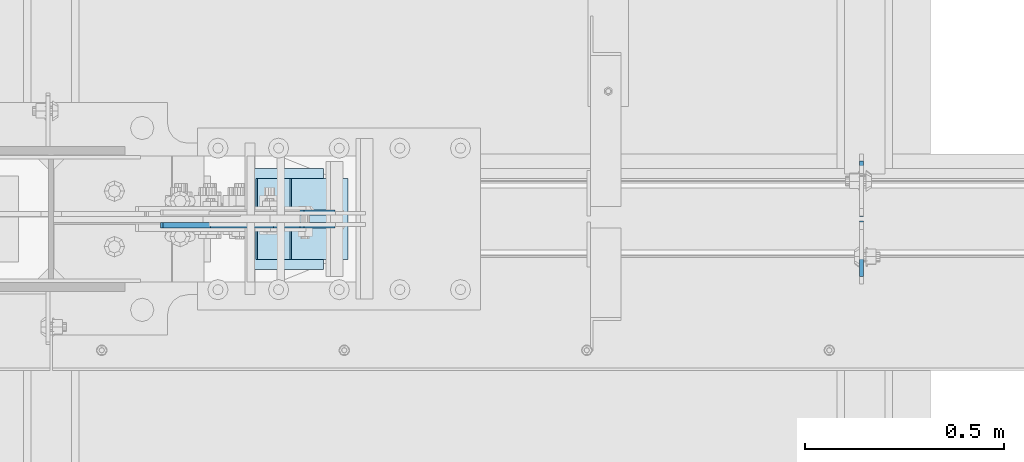
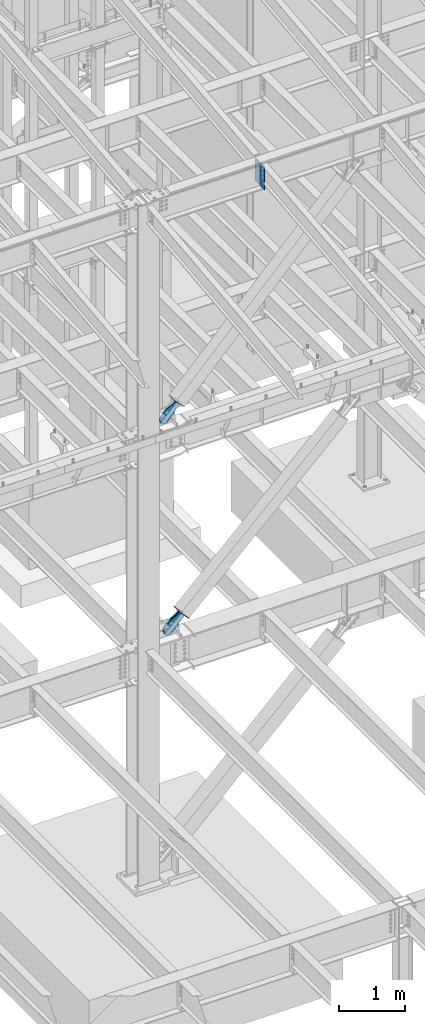
# One storey, part 1029 of 1179: 8 plates, 7 elements without a shape of their own.
"""IFC2X3 building model written with IfcOpenShell, lengths in millimetres."""

import ifcopenshell
import ifcopenshell.guid

model = None  # the IFC model being written
_history = None  # IfcOwnerHistory: only IFC2X3 demands one
_inside = {}  # id of a spatial element -> (the spatial element, [elements in it])
_under = {}  # id of a project, library or spatial element -> (it, [spatial elements below it])
_declared = {}  # id of a project -> (the project, [libraries it declares])
_typed = {}  # id of a type object -> (the type object, [elements of that type])
_made_of = {}  # id of a material, layer set ... -> (it, [elements and type objects made of it])


def new_model(schema):
    """Start an empty IFC model of exactly this schema.

    Asked for "IFC4X3", IfcOpenShell would pick the latest addendum, in which some entities
    have other attributes; the version numbers below select the first issue.
    IFC2X3 requires an IfcOwnerHistory on every rooted entity: one is made here for all.
    """
    global model, _history
    if schema == "IFC4X3":
        model = ifcopenshell.file(schema_version=(4, 3, 0, 0))
    else:
        model = ifcopenshell.file(schema=schema)
    _inside.clear()
    _under.clear()
    _declared.clear()
    _typed.clear()
    _made_of.clear()
    _history = None
    if model.schema == "IFC2X3":
        org = make("IfcOrganization", Name="unknown")
        user = make(
            "IfcPersonAndOrganization",
            ThePerson=make("IfcPerson", FamilyName="unknown"),
            TheOrganization=org,
        )
        app = make(
            "IfcApplication",
            ApplicationDeveloper=org,
            Version="unknown",
            ApplicationFullName="unknown",
            ApplicationIdentifier="unknown",
        )
        _history = make(
            "IfcOwnerHistory",
            OwningUser=user,
            OwningApplication=app,
            ChangeAction="ADDED",
            CreationDate=0,
        )
    return model


def make(cls, **values):
    """One entity of the class cls with the attributes given. An attribute that is None is left unset."""
    return model.create_entity(
        cls, **{name: value for name, value in values.items() if value is not None}
    )


def rooted(cls, **values):
    """An entity with a GlobalId (a new one), such as an element, a storey or a relation."""
    return make(cls, GlobalId=ifcopenshell.guid.new(), OwnerHistory=_history, **values)


def si_unit(unit_type, name, prefix=None):
    """IfcSIUnit, for example si_unit("LENGTHUNIT", "METRE", prefix="MILLI")."""
    return make("IfcSIUnit", UnitType=unit_type, Prefix=prefix, Name=name)


def assignment(units):
    """IfcUnitAssignment: the units of a project."""
    return None if units is None else make("IfcUnitAssignment", Units=units)


def point(xyz):
    """IfcCartesianPoint."""
    return None if xyz is None else make("IfcCartesianPoint", Coordinates=xyz)


def direction(xyz):
    """IfcDirection."""
    return None if xyz is None else make("IfcDirection", DirectionRatios=xyz)


def frame(location, z_axis=None, x_axis=None):
    """IfcAxis2Placement3D, a coordinate frame: its origin and axes. An axis left out is left unset."""
    return make(
        "IfcAxis2Placement3D",
        Location=point(location),
        Axis=direction(z_axis),
        RefDirection=direction(x_axis),
    )


def origin_with_axes():
    """The frame at (0, 0, 0) with the z axis (0, 0, 1) and the x axis (1, 0, 0) written out."""
    return frame((0.0, 0.0, 0.0), z_axis=(0.0, 0.0, 1.0), x_axis=(1.0, 0.0, 0.0))


def place(relative_to, where):
    """IfcLocalPlacement: puts the frame where relative to a parent placement (None: the world)."""
    return make(
        "IfcLocalPlacement", PlacementRelTo=relative_to, RelativePlacement=where
    )


def context(
    kind, dimensions, precision=None, world=None, true_north=None, identifier=None
):
    """IfcGeometricRepresentationContext, for example the 3D "Model" context."""
    return make(
        "IfcGeometricRepresentationContext",
        ContextIdentifier=identifier,
        ContextType=kind,
        CoordinateSpaceDimension=dimensions,
        Precision=precision,
        WorldCoordinateSystem=world,
        TrueNorth=true_north,
    )


def subcontext(parent, identifier, kind, view, scale=None):
    """IfcGeometricRepresentationSubContext, for example "Body" below "Model"."""
    return make(
        "IfcGeometricRepresentationSubContext",
        ContextIdentifier=identifier,
        ContextType=kind,
        ParentContext=parent,
        TargetScale=scale,
        TargetView=view,
    )


def project(units=None, contexts=None):
    """IfcProject with its units and contexts."""
    return rooted(
        "IfcProject",
        Name="project",
        RepresentationContexts=contexts,
        UnitsInContext=assignment(units),
    )


def spatial(cls, under=None, at=None, **own):
    """A site, building, storey or space (cls), placed at a placement, below another one or the project."""
    s = rooted(cls, ObjectPlacement=at, **own)
    if under is not None:
        _under.setdefault(under.id(), (under, []))[1].append(s)
    return s


def faces_of(points, faces, orient=None, outer=None):
    """IfcFace entities. A face is a list of loops; a loop is a list of indices into points, from 0.

    orient and outer hold one flag for each loop. By default every Orientation is true, the
    first loop of a face is its IfcFaceOuterBound and the others are IfcFaceBound.
    """
    made = []
    for i, loops in enumerate(faces):
        bounds = []
        for j, loop in enumerate(loops):
            is_outer = j == 0 if outer is None else outer[i][j]
            bounds.append(
                make(
                    "IfcFaceOuterBound" if is_outer else "IfcFaceBound",
                    Bound=make("IfcPolyLoop", Polygon=[points[k] for k in loop]),
                    Orientation=True if orient is None else orient[i][j],
                )
            )
        made.append(make("IfcFace", Bounds=bounds))
    return made


def faceted_brep(points, faces, orient=None, outer=None, voids=None):
    """IfcFacetedBrep: a solid bounded by flat faces; with voids (closed shells), ...WithVoids."""
    shared = [point(p) for p in points]
    hull = make("IfcClosedShell", CfsFaces=faces_of(shared, faces, orient, outer))
    if voids is None:
        return make("IfcFacetedBrep", Outer=hull)
    return make(
        "IfcFacetedBrepWithVoids",
        Outer=hull,
        Voids=[
            make(cls, CfsFaces=faces_of(shared, fs, o, b)) for cls, fs, o, b in voids
        ],
    )


def shape(context_of_items, identifier, shape_type, items):
    """IfcShapeRepresentation: the items that make up one representation, for example the "Body"."""
    return make(
        "IfcShapeRepresentation",
        ContextOfItems=context_of_items,
        RepresentationIdentifier=identifier,
        RepresentationType=shape_type,
        Items=items,
    )


def material(Name=None, Category=None):
    """IfcMaterial."""
    return make("IfcMaterial", Name=Name, Category=Category)


def made_of(thing, what):
    """Note that an element or type object is made of a material, layer set ...; save() writes the relation."""
    if what is not None:
        _made_of.setdefault(what.id(), (what, []))[1].append(thing)
    return thing


def type_object(cls, material=None, **own):
    """A type object (cls), such as IfcWallType, which elements share."""
    return made_of(rooted(cls, **own), material)


def element(
    cls,
    number,
    at=None,
    inside=None,
    cuts=None,
    type_object=None,
    material=None,
    context=None,
    identifier="Body",
    shape_type=None,
    held_by="IfcProductDefinitionShape",
    body=None,
    shapes=None,
    **own,
):
    """One element of the class cls, such as IfcWall. Its Tag is "e" and its number.

    at: its placement. inside: the storey or other place that contains it. cuts: it is an
    opening in that element (IfcRelVoidsElement). A single representation is given by context,
    identifier, shape_type and body (its items); several are given by shapes. held_by: the class
    of the entity that holds the representations. save() writes the other relations.
    """
    e = rooted(cls, Tag="e%d" % number, ObjectPlacement=at, **own)
    if body is not None:
        shapes = [shape(context, identifier, shape_type, body)]
    if shapes is not None:
        e.Representation = make(held_by, Representations=shapes)
    if inside is not None:
        _inside.setdefault(inside.id(), (inside, []))[1].append(e)
    if cuts is not None:
        rooted(
            "IfcRelVoidsElement", RelatingBuildingElement=cuts, RelatedOpeningElement=e
        )
    if type_object is not None:
        _typed.setdefault(type_object.id(), (type_object, []))[1].append(e)
    return made_of(e, material)


def aggregate(whole, parts):
    """IfcRelAggregates: a whole, such as a stair, and the parts it consists of."""
    return rooted("IfcRelAggregates", RelatingObject=whole, RelatedObjects=parts)


def save(model, path):
    """Write the relations noted so far, then the file.

    IfcRelAggregates (storeys below a building ...), IfcRelContainedInSpatialStructure (elements
    in a storey), IfcRelDefinesByType, IfcRelAssociatesMaterial and IfcRelDeclares: one each for
    every whole, place, type object, material and project.
    """
    for whole, parts in _under.values():
        aggregate(whole, parts)
    for where, things in _inside.values():
        rooted(
            "IfcRelContainedInSpatialStructure",
            RelatedElements=things,
            RelatingStructure=where,
        )
    for kind, things in _typed.values():
        rooted("IfcRelDefinesByType", RelatedObjects=things, RelatingType=kind)
    for what, things in _made_of.values():
        rooted("IfcRelAssociatesMaterial", RelatedObjects=things, RelatingMaterial=what)
    for by, libraries in _declared.values():
        rooted("IfcRelDeclares", RelatingContext=by, RelatedDefinitions=libraries)
    model.write(path)


model = new_model("IFC2X3")

# Units and contexts
model_context = context("Model", 3, precision=1e-05, world=origin_with_axes())
body_context = subcontext(model_context, "Body", "Model", "MODEL_VIEW")
ifc_project = project(units=[si_unit("LENGTHUNIT", "METRE", prefix="MILLI"), si_unit("AREAUNIT", "SQUARE_METRE"), si_unit("VOLUMEUNIT", "CUBIC_METRE"), si_unit("MASSUNIT", "GRAM", prefix="KILO"), si_unit("TIMEUNIT", "SECOND"), si_unit("PLANEANGLEUNIT", "RADIAN"), si_unit("SOLIDANGLEUNIT", "STERADIAN"), si_unit("THERMODYNAMICTEMPERATUREUNIT", "DEGREE_CELSIUS"), si_unit("LUMINOUSINTENSITYUNIT", "LUMEN")], contexts=[model_context])

# Site, building, storey
site_placement = place(None, origin_with_axes())
site = spatial("IfcSite", under=ifc_project, at=site_placement, CompositionType="ELEMENT")
building_placement = place(site_placement, origin_with_axes())
building = spatial("IfcBuilding", under=site, at=building_placement, Name="Undefined", CompositionType="ELEMENT")
storey_placement = place(building_placement, origin_with_axes())
storey = spatial("IfcBuildingStorey", under=building, at=storey_placement, Name="Undefined", CompositionType="ELEMENT", Elevation=0.0)

# Assembly, plate
assembly_1_placement = place(storey_placement, origin_with_axes())
assembly_1 = element("IfcElementAssembly", 1, at=assembly_1_placement, inside=storey, AssemblyPlace="NOTDEFINED", PredefinedType="RIGID_FRAME")
ifc_material = material(Name="STEEL/A36")
plate_type_1 = type_object("IfcPlateType", PredefinedType="NOTDEFINED")
plate_1_placement = place(assembly_1_placement, frame((8848.95548700398, 27035.125, 8270.04204745431), z_axis=(-0.724386095169387, 0.0, 0.689394506161203), x_axis=(0.689394506161203, 0.0, 0.724386095169387)))
plate_1 = element("IfcPlate", 2, at=plate_1_placement, type_object=plate_type_1, material=ifc_material, context=body_context, shape_type="Brep", body=[
    faceted_brep([(0.0, -6.34999999999854, 0.0), (-101.600000000211, -6.34999999999854, -44.6881937825565), (-101.600000000211, 6.34999999999854, -44.6881937825565), (0.0, 6.34999999999854, 0.0), (-246.684985848258, -6.34999999999854, -44.6881937827675), (-246.684985848258, 6.34999999999854, -44.6881937827675), (-281.313054102191, -6.34999999999854, -37.800242748639), (-281.313054102191, 6.34999999999854, -37.800242748639), (-310.669312868691, -6.34999999999854, -18.1850177516608), (-310.669312868691, 6.34999999999854, -18.1850177516608), (-330.284537865713, -6.34999999999854, 11.1712410148393), (-330.284537865713, 6.34999999999854, 11.1712410148393), (-337.172488899912, -6.34999999999854, 45.7993031647638), (-337.172488899912, 6.34999999999854, 45.7993031647638), (-330.284537865768, -6.34999999999854, 80.4273714187839), (-330.284537865768, 6.34999999999854, 80.4273714187839), (-310.669312868773, -6.34999999999854, 109.783630185371), (-310.669312868773, 6.34999999999854, 109.783630185371), (-281.313054102271, -6.34999999999854, 129.398855182466), (-281.313054102271, 6.34999999999854, 129.398855182466), (-246.684988899762, -6.34999999999854, 136.286806216707), (-246.684988899762, 6.34999999999854, 136.286806216707), (-101.600000000377, -6.34999999999854, 136.286806216911), (-101.600000000377, 6.34999999999854, 136.286806216911), (-8.18545231595635e-11, -6.34999999999854, 91.5986124346418), (-8.18545231595635e-11, 6.34999999999854, 91.5986124346418), (82.5500000001266, -6.34999999999854, 91.5986124347546), (82.5500000001266, 6.34999999999854, 91.5986124347546), (82.550000000203, -6.34999999999854, 1.2732925824821e-10), (82.550000000203, 6.34999999999854, 1.2732925824821e-10)], [[[0, 1, 2, 3]], [[1, 4, 5, 2]], [[4, 6, 7, 5]], [[6, 8, 9, 7]], [[8, 10, 11, 9]], [[10, 12, 13, 11]], [[12, 14, 15, 13]], [[14, 16, 17, 15]], [[16, 18, 19, 17]], [[18, 20, 21, 19]], [[20, 22, 23, 21]], [[22, 24, 25, 23]], [[24, 26, 27, 25]], [[26, 28, 29, 27]], [[28, 0, 3, 29]], [[5, 7, 9, 11, 13, 15, 17, 19, 21, 23, 25, 27, 29, 3, 2]], [[28, 26, 24, 22, 20, 18, 16, 14, 12, 10, 8, 6, 4, 1, 0]]]),
])
aggregate(assembly_1, [plate_1])

assembly_2_placement = place(storey_placement, origin_with_axes())
assembly_2 = element("IfcElementAssembly", 3, at=assembly_2_placement, inside=storey, Name="Plate", AssemblyPlace="NOTDEFINED", PredefinedType="RIGID_FRAME")
plate_type_2 = type_object("IfcPlateType", PredefinedType="NOTDEFINED")
plate_2_placement = place(assembly_2_placement, frame((8944.0974226088, 26949.4, 8289.07150202462), z_axis=(-0.724386095169387, 0.0, 0.689394506161203), x_axis=(0.0, 1.0, 0.0)))
plate_2 = element("IfcPlate", 4, at=plate_2_placement, type_object=plate_type_2, material=ifc_material, Name="Plate", context=body_context, shape_type="Brep", body=[
    faceted_brep([(0.0, -3.17500000000109, 0.0), (0.0, -3.17500000000291, 203.200000000368), (0.0, 3.17499999998836, 203.200000000361), (0.0, 3.17500000000109, 7.27595761418343e-12), (203.199999999997, -3.17500000000291, 203.200000000368), (203.199999999997, 3.17499999998836, 203.200000000361), (203.199999999997, -3.17499999999927, 3.63797880709171e-12), (203.199999999997, 3.17499999999382, -3.63797880709171e-12)], [[[0, 1, 2, 3]], [[1, 4, 5, 2]], [[4, 6, 7, 5]], [[6, 0, 3, 7]], [[5, 7, 3, 2]], [[6, 4, 1, 0]]]),
])
aggregate(assembly_2, [plate_2])

assembly_3_placement = place(storey_placement, origin_with_axes())
assembly_3 = element("IfcElementAssembly", 5, at=assembly_3_placement, inside=storey, Name="Plate", AssemblyPlace="NOTDEFINED", PredefinedType="RIGID_FRAME")
plate_3_placement = place(assembly_3_placement, frame((9023.59478559862, 26949.4, 4367.90703055063), z_axis=(-0.694497308871752, 0.0, 0.719495300867138), x_axis=(0.0, 1.0, 0.0)))
plate_3 = element("IfcPlate", 6, at=plate_3_placement, type_object=plate_type_2, material=ifc_material, Name="Plate", context=body_context, shape_type="Brep", body=[
    faceted_brep([(0.0, -3.17500000000109, 0.0), (0.0, -3.17500000000291, 203.200000000368), (0.0, 3.17499999998836, 203.200000000361), (0.0, 3.17500000000109, 7.27595761418343e-12), (203.199999999997, -3.17500000000291, 203.200000000368), (203.199999999997, 3.17499999998836, 203.200000000361), (203.199999999997, -3.17499999999927, 3.63797880709171e-12), (203.199999999997, 3.17499999999382, -3.63797880709171e-12)], [[[0, 1, 2, 3]], [[1, 4, 5, 2]], [[4, 6, 7, 5]], [[6, 0, 3, 7]], [[5, 7, 3, 2]], [[6, 4, 1, 0]]]),
])
aggregate(assembly_3, [plate_3])

# Assembly, plates
assembly_4_placement = place(storey_placement, origin_with_axes())
assembly_4 = element("IfcElementAssembly", 7, at=assembly_4_placement, inside=storey, Name="BEAM", AssemblyPlace="NOTDEFINED", PredefinedType="RIGID_FRAME")
plate_type_3 = type_object("IfcPlateType", PredefinedType="NOTDEFINED")
plate_4_placement = place(assembly_4_placement, frame((10317.1620000839, 27045.4437499701, 11823.3031250357), z_axis=(0.0, 0.0, 1.0), x_axis=(0.0, -1.0, 0.0)))
plate_4 = element("IfcPlate", 8, at=plate_4_placement, type_object=plate_type_3, material=ifc_material, Name="PLATE", context=body_context, shape_type="Brep", body=[
    faceted_brep([(-1.81898940354586e-12, -4.76249999999345, 17.4624996185303), (0.0, -4.76250000000073, 407.98750038147), (0.0, 4.76250000000073, 407.98750038147), (1.81898940354586e-12, 4.76250000000073, 17.4624996185303), (17.4624996185303, -4.76250000000073, 425.450000000001), (17.4624996185303, 4.76250000000073, 425.450000000001), (139.699999999997, -4.76250000000073, 425.450000000001), (139.699999999997, 4.76250000000073, 425.450000000001), (139.7, -4.76249999999982, 0.0), (139.7, 4.76249999999982, 0.0), (17.4624996185157, -4.76250000000073, 0.0), (17.4624996185212, 4.76249999999345, 0.0)], [[[0, 1, 2, 3]], [[1, 4, 5, 2]], [[4, 6, 7, 5]], [[6, 8, 9, 7]], [[8, 10, 11, 9]], [[10, 0, 3, 11]], [[5, 7, 9, 11, 3, 2]], [[10, 8, 6, 4, 1, 0]]]),
])
plate_5_placement = place(assembly_4_placement, frame((10317.1620000839, 27056.5562499701, 11823.3031250357), z_axis=(0.0, 0.0, 1.0), x_axis=(0.0, 1.0, 0.0)))
plate_5 = element("IfcPlate", 9, at=plate_5_placement, type_object=plate_type_3, material=ifc_material, Name="PLATE", context=body_context, shape_type="Brep", body=[
    faceted_brep([(-1.81898940354586e-12, -4.76249999999345, 17.4624996185303), (0.0, -4.76250000000073, 407.98750038147), (0.0, 4.76250000000073, 407.98750038147), (1.81898940354586e-12, 4.76250000000073, 17.4624996185303), (17.4624996185303, -4.76250000000073, 425.450000000001), (17.4624996185303, 4.76250000000073, 425.450000000001), (139.699999999997, -4.76250000000073, 425.450000000001), (139.699999999997, 4.76250000000073, 425.450000000001), (139.7, -4.76249999999982, 0.0), (139.7, 4.76249999999982, 0.0), (17.4624996185157, -4.76250000000073, 0.0), (17.4624996185212, 4.76249999999345, 0.0)], [[[0, 1, 2, 3]], [[1, 4, 5, 2]], [[4, 6, 7, 5]], [[6, 8, 9, 7]], [[8, 10, 11, 9]], [[10, 0, 3, 11]], [[5, 7, 9, 11, 3, 2]], [[10, 8, 6, 4, 1, 0]]]),
])
aggregate(assembly_4, [plate_4, plate_5])

# Assembly, plate
assembly_5_placement = place(storey_placement, origin_with_axes())
assembly_5 = element("IfcElementAssembly", 10, at=assembly_5_placement, inside=storey, AssemblyPlace="NOTDEFINED", PredefinedType="RIGID_FRAME")
plate_type_4 = type_object("IfcPlateType", PredefinedType="NOTDEFINED")
plate_6_placement = place(assembly_5_placement, frame((8934.87998578012, 27066.875, 4345.52376395533), z_axis=(-0.694497308871752, 0.0, 0.719495300867138), x_axis=(0.719495300867139, 0.0, 0.694497308871752)))
plate_6 = element("IfcPlate", 11, at=plate_6_placement, type_object=plate_type_4, material=ifc_material, context=body_context, shape_type="Brep", body=[
    faceted_brep([(0.0, -6.34999999999854, 0.0), (-101.599999999963, -6.34999999999854, -37.5700345970108), (-101.599999999963, 6.34999999999854, -37.5700345970108), (0.0, 6.34999999999854, 0.0), (-245.369242323884, -6.34999999999854, -37.5700345970945), (-245.369242323884, 6.34999999999854, -37.5700345970945), (-281.212328723803, -6.34999999999854, -30.4404014271258), (-281.212328723803, 6.34999999999854, -30.4404014271258), (-311.598630137756, -6.34999999999854, -10.1369239370142), (-311.598630137756, 6.34999999999854, -10.1369239370142), (-331.902107627997, -6.34999999999854, 20.24937747687), (-331.902107627997, 6.34999999999854, 20.24937747687), (-339.031740798124, -6.34999999999854, 56.0924669287269), (-339.031740798124, 6.34999999999854, 56.0924669287269), (-331.902107628228, -6.34999999999854, 91.9355533287926), (-331.902107628228, 6.34999999999854, 91.9355533287926), (-311.598630138099, -6.34999999999854, 122.321854742866), (-311.598630138099, 6.34999999999854, 122.321854742866), (-281.212328724136, -6.34999999999854, 142.625332233139), (-281.212328724136, 6.34999999999854, 142.625332233139), (-245.36924079839, -6.34999999999854, 149.754965403199), (-245.36924079839, 6.34999999999854, 149.754965403199), (-101.600000000685, -6.34999999999854, 149.75496540329), (-101.600000000685, 6.34999999999854, 149.75496540329), (-4.35647962149233e-10, -6.34999999999854, 112.184930806416), (-4.35647962149233e-10, 6.34999999999854, 112.184930806416), (82.5499999996491, -6.34999999999854, 112.184930806461), (82.5499999996491, 6.34999999999854, 112.184930806461), (82.550000000203, -6.34999999999854, 1.2732925824821e-10), (82.550000000203, 6.34999999999854, 1.2732925824821e-10)], [[[0, 1, 2, 3]], [[1, 4, 5, 2]], [[4, 6, 7, 5]], [[6, 8, 9, 7]], [[8, 10, 11, 9]], [[10, 12, 13, 11]], [[12, 14, 15, 13]], [[14, 16, 17, 15]], [[16, 18, 19, 17]], [[18, 20, 21, 19]], [[20, 22, 23, 21]], [[22, 24, 25, 23]], [[24, 26, 27, 25]], [[26, 28, 29, 27]], [[28, 0, 3, 29]], [[5, 7, 9, 11, 13, 15, 17, 19, 21, 23, 25, 27, 29, 3, 2]], [[28, 26, 24, 22, 20, 18, 16, 14, 12, 10, 8, 6, 4, 1, 0]]]),
])
aggregate(assembly_5, [plate_6])

assembly_6_placement = place(storey_placement, origin_with_axes())
assembly_6 = element("IfcElementAssembly", 12, at=assembly_6_placement, inside=storey, AssemblyPlace="NOTDEFINED", PredefinedType="RIGID_FRAME")
plate_7_placement = place(assembly_6_placement, frame((8934.87998578012, 27035.125, 4345.52376395533), z_axis=(-0.694497308871752, 0.0, 0.719495300867138), x_axis=(0.719495300867139, 0.0, 0.694497308871752)))
plate_7 = element("IfcPlate", 13, at=plate_7_placement, type_object=plate_type_4, material=ifc_material, context=body_context, shape_type="Brep", body=[
    faceted_brep([(0.0, -6.34999999999854, 0.0), (-101.599999999963, -6.34999999999854, -37.5700345970108), (-101.599999999963, 6.34999999999854, -37.5700345970108), (0.0, 6.34999999999854, 0.0), (-245.369242323884, -6.34999999999854, -37.5700345970945), (-245.369242323884, 6.34999999999854, -37.5700345970945), (-281.212328723803, -6.34999999999854, -30.4404014271258), (-281.212328723803, 6.34999999999854, -30.4404014271258), (-311.598630137756, -6.34999999999854, -10.1369239370142), (-311.598630137756, 6.34999999999854, -10.1369239370142), (-331.902107627997, -6.34999999999854, 20.24937747687), (-331.902107627997, 6.34999999999854, 20.24937747687), (-339.031740798124, -6.34999999999854, 56.0924669287269), (-339.031740798124, 6.34999999999854, 56.0924669287269), (-331.902107628228, -6.34999999999854, 91.9355533287926), (-331.902107628228, 6.34999999999854, 91.9355533287926), (-311.598630138099, -6.34999999999854, 122.321854742866), (-311.598630138099, 6.34999999999854, 122.321854742866), (-281.212328724136, -6.34999999999854, 142.625332233139), (-281.212328724136, 6.34999999999854, 142.625332233139), (-245.36924079839, -6.34999999999854, 149.754965403199), (-245.36924079839, 6.34999999999854, 149.754965403199), (-101.600000000685, -6.34999999999854, 149.75496540329), (-101.600000000685, 6.34999999999854, 149.75496540329), (-4.35647962149233e-10, -6.34999999999854, 112.184930806416), (-4.35647962149233e-10, 6.34999999999854, 112.184930806416), (82.5499999996491, -6.34999999999854, 112.184930806461), (82.5499999996491, 6.34999999999854, 112.184930806461), (82.550000000203, -6.34999999999854, 1.2732925824821e-10), (82.550000000203, 6.34999999999854, 1.2732925824821e-10)], [[[0, 1, 2, 3]], [[1, 4, 5, 2]], [[4, 6, 7, 5]], [[6, 8, 9, 7]], [[8, 10, 11, 9]], [[10, 12, 13, 11]], [[12, 14, 15, 13]], [[14, 16, 17, 15]], [[16, 18, 19, 17]], [[18, 20, 21, 19]], [[20, 22, 23, 21]], [[22, 24, 25, 23]], [[24, 26, 27, 25]], [[26, 28, 29, 27]], [[28, 0, 3, 29]], [[5, 7, 9, 11, 13, 15, 17, 19, 21, 23, 25, 27, 29, 3, 2]], [[28, 26, 24, 22, 20, 18, 16, 14, 12, 10, 8, 6, 4, 1, 0]]]),
])
aggregate(assembly_6, [plate_7])

assembly_7_placement = place(storey_placement, origin_with_axes())
assembly_7 = element("IfcElementAssembly", 14, at=assembly_7_placement, inside=storey, Name="Plate", AssemblyPlace="NOTDEFINED", PredefinedType="RIGID_FRAME")
plate_type_5 = type_object("IfcPlateType", PredefinedType="NOTDEFINED")
plate_8_placement = place(assembly_7_placement, frame((8963.12193986124, 26924.0, 275.238706534023), z_axis=(-0.699860687134476, 0.0, 0.714279370137245), x_axis=(0.0, 1.0, 0.0)))
plate_8 = element("IfcPlate", 15, at=plate_8_placement, type_object=plate_type_5, material=ifc_material, Name="Plate", context=body_context, shape_type="Brep", body=[
    faceted_brep([(0.0, -3.17500000000109, 0.0), (0.0, -3.17499999986103, 253.99999999967), (0.0, 3.17500000013752, 253.999999999668), (0.0, 3.17500000000109, 7.27595761418343e-12), (254.0, -3.17499999986103, 253.99999999967), (254.0, 3.17500000013752, 253.999999999668), (254.0, -3.17500000000109, 9.09494701772928e-13), (254.0, 3.17499999999745, -1.36424205265939e-12)], [[[0, 1, 2, 3]], [[1, 4, 5, 2]], [[4, 6, 7, 5]], [[6, 0, 3, 7]], [[5, 7, 3, 2]], [[6, 4, 1, 0]]]),
])
aggregate(assembly_7, [plate_8])

save(model, "model.ifc")
